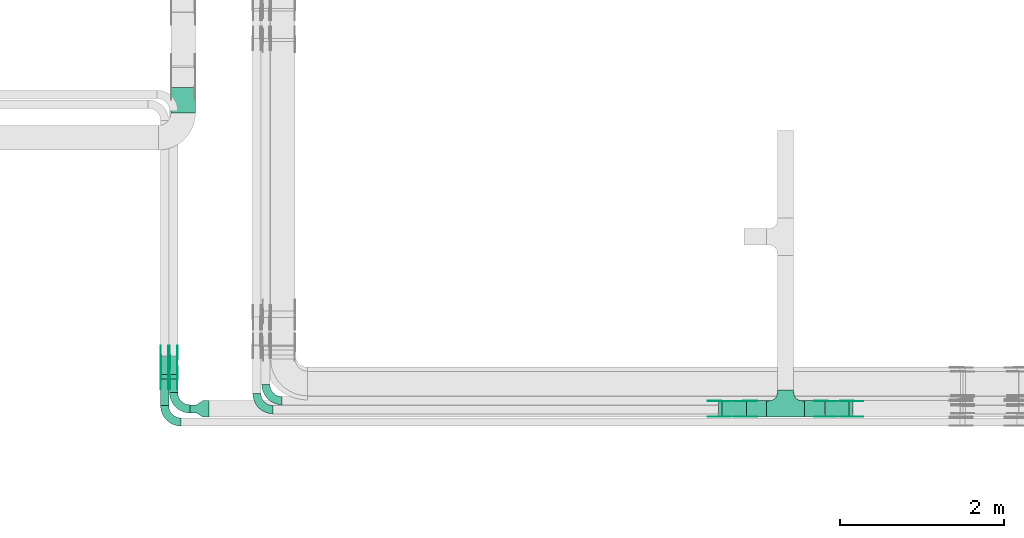
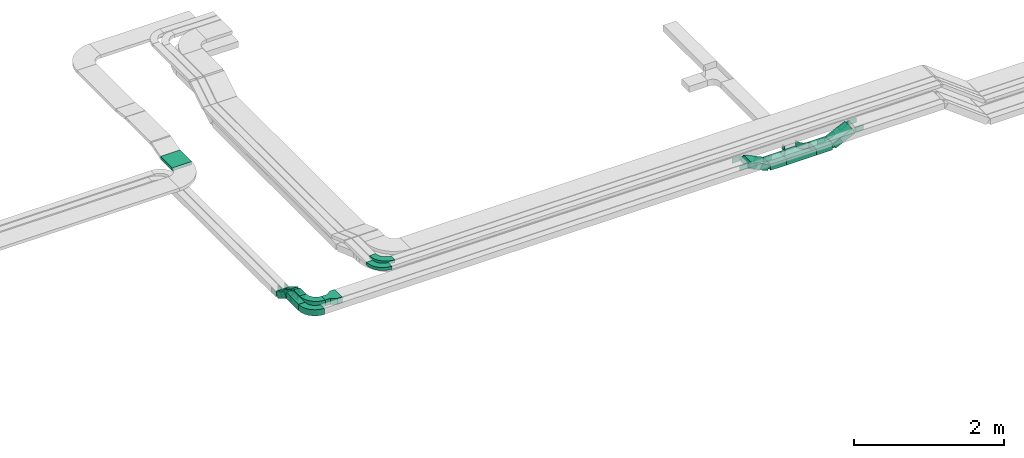
# One storey, part 6 of 28: 38 flow fittings, 9 flow segments.
"""IFC2X3 building model written with IfcOpenShell, lengths in millimetres."""

from ifc_helpers import new_model, entity, si_unit, converted_unit, derived_unit, direction, frame, frame_2d, origin, place, context, subcontext, project, spatial, polyline, circle_curve, parameter, trimmed, segment, composite_curve, rectangle, outline, extrude, faceted_brep, source, transform, mapped, material, type_object, type_shapes, element, save


model = new_model("IFC2X3")

# Units and contexts
model_context = context("Model", 3, precision=0.01, world=origin(), true_north=direction((6.12303176911189e-17, 1.0)))
body_context = subcontext(model_context, "Body", "Model", "MODEL_VIEW")
ifc_project = project(units=[si_unit("LENGTHUNIT", "METRE", prefix="MILLI"), si_unit("AREAUNIT", "SQUARE_METRE"), si_unit("VOLUMEUNIT", "CUBIC_METRE"), converted_unit("PLANEANGLEUNIT", "DEGREE", entity("IfcRatioMeasure", 0.0174532925199433), si_unit("PLANEANGLEUNIT", "RADIAN"), dimensions=[0, 0, 0, 0, 0, 0, 0]), si_unit("MASSUNIT", "GRAM", prefix="KILO"), derived_unit("MASSDENSITYUNIT", [(si_unit("MASSUNIT", "GRAM", prefix="KILO"), 1), (si_unit("LENGTHUNIT", "METRE"), -3)]), derived_unit("MOMENTOFINERTIAUNIT", [(si_unit("LENGTHUNIT", "METRE"), 4)]), si_unit("TIMEUNIT", "SECOND"), si_unit("FREQUENCYUNIT", "HERTZ"), si_unit("THERMODYNAMICTEMPERATUREUNIT", "DEGREE_CELSIUS"), derived_unit("THERMALTRANSMITTANCEUNIT", [(si_unit("MASSUNIT", "GRAM", prefix="KILO"), 1), (si_unit("THERMODYNAMICTEMPERATUREUNIT", "KELVIN"), -1), (si_unit("TIMEUNIT", "SECOND"), -3)]), derived_unit("VOLUMETRICFLOWRATEUNIT", [(si_unit("LENGTHUNIT", "METRE"), 3), (si_unit("TIMEUNIT", "SECOND"), -1)]), derived_unit("MASSFLOWRATEUNIT", [(si_unit("MASSUNIT", "GRAM", prefix="KILO"), 1), (si_unit("TIMEUNIT", "SECOND"), -1)]), derived_unit("ROTATIONALFREQUENCYUNIT", [(si_unit("TIMEUNIT", "SECOND"), -1)]), si_unit("ELECTRICCURRENTUNIT", "AMPERE"), si_unit("ELECTRICVOLTAGEUNIT", "VOLT"), si_unit("POWERUNIT", "WATT"), si_unit("FORCEUNIT", "NEWTON", prefix="KILO"), si_unit("ILLUMINANCEUNIT", "LUX"), si_unit("LUMINOUSFLUXUNIT", "LUMEN"), si_unit("LUMINOUSINTENSITYUNIT", "CANDELA"), derived_unit("USERDEFINED", [(si_unit("MASSUNIT", "GRAM", prefix="KILO"), -1), (si_unit("LENGTHUNIT", "METRE"), -2), (si_unit("TIMEUNIT", "SECOND"), 3), (si_unit("LUMINOUSFLUXUNIT", "LUMEN"), 1)]), derived_unit("LINEARVELOCITYUNIT", [(si_unit("LENGTHUNIT", "METRE"), 1), (si_unit("TIMEUNIT", "SECOND"), -1)]), si_unit("PRESSUREUNIT", "PASCAL"), derived_unit("USERDEFINED", [(si_unit("LENGTHUNIT", "METRE"), -2), (si_unit("MASSUNIT", "GRAM", prefix="KILO"), 1), (si_unit("TIMEUNIT", "SECOND"), -2)]), derived_unit("LINEARFORCEUNIT", [(si_unit("MASSUNIT", "GRAM", prefix="KILO"), 1), (si_unit("LENGTHUNIT", "METRE"), 1), (si_unit("TIMEUNIT", "SECOND"), -2), (si_unit("LENGTHUNIT", "METRE"), -1)]), derived_unit("PLANARFORCEUNIT", [(si_unit("MASSUNIT", "GRAM", prefix="KILO"), 1), (si_unit("LENGTHUNIT", "METRE"), 1), (si_unit("TIMEUNIT", "SECOND"), -2), (si_unit("LENGTHUNIT", "METRE"), -2)])], contexts=[model_context])

# Site, building, storey
site_placement = place(None, frame((0.0, -0.00077364408347762, 0.0)))
site = spatial("IfcSite", under=ifc_project, at=site_placement, CompositionType="ELEMENT")
building_placement = place(site_placement, origin())
building = spatial("IfcBuilding", under=site, at=building_placement, CompositionType="ELEMENT")
storey_placement = place(building_placement, origin())
storey = spatial("IfcBuildingStorey", under=building, at=storey_placement, CompositionType="ELEMENT", Elevation=0.0)

# Flow segments
cable_carrier_segment_type = type_object("IfcCableCarrierSegmentType", PredefinedType="CABLETRAYSEGMENT")
flow_segment_1_placement = place(storey_placement, frame((21923.5985265898, 8360.00006103512, 2950.0)))
element("IfcFlowSegment", 1, at=flow_segment_1_placement, inside=storey, type_object=cable_carrier_segment_type, context=body_context, shape_type="SweptSolid", body=[
    extrude(rectangle(XDim=246.307781920358, YDim=200.0, at=frame_2d((-2.1600499167107e-12, -5.47117906535277e-13), x_axis=(1.0, 0.0))), frame((123.153890960181, 100.0, 0.0)), (0.0, 0.0, 1.0), 100.0),
])
flow_segment_2_placement = place(storey_placement, frame((21217.2907446694, 8360.00006103512, 2950.0)))
element("IfcFlowSegment", 2, at=flow_segment_2_placement, inside=storey, type_object=cable_carrier_segment_type, context=body_context, shape_type="SweptSolid", body=[
    extrude(rectangle(XDim=246.307781920462, YDim=200.0, at=frame_2d((2.16715534406831e-12, 0.0), x_axis=(1.0, 0.0))), frame((123.153890960233, 100.0, 0.0), z_axis=(0.0, 0.0, 1.0), x_axis=(-1.0, 0.0, 0.0)), (0.0, 0.0, 1.0), 100.0),
])
flow_segment_3_placement = place(storey_placement, frame((22173.5030893442, 8360.00006103512, 2960.16660840991)))
element("IfcFlowSegment", 3, at=flow_segment_3_placement, inside=storey, type_object=cable_carrier_segment_type, context=body_context, shape_type="SweptSolid", body=[
    extrude(rectangle(XDim=100.000000000001, YDim=200.0, at=frame_2d((0.0, 1.08713038571295e-12), x_axis=(1.0, 0.0))), frame((21.1309130870434, 100.0, 45.3153893518315), z_axis=(0.906307787036594, 0.0, 0.42261826174082), x_axis=(-0.42261826174082, 0.0, 0.906307787036594)), (0.0, 0.0, 1.0), 328.987213909019),
])
flow_segment_4_placement = place(storey_placement, frame((20873.2684638601, 8360.00006103512, 2960.16660840991)))
element("IfcFlowSegment", 4, at=flow_segment_4_placement, inside=storey, type_object=cable_carrier_segment_type, context=body_context, shape_type="SweptSolid", body=[
    extrude(rectangle(XDim=100.000000000001, YDim=200.0, at=frame_2d((0.0, 0.0), x_axis=(0.0, 1.0))), frame((21.1309130870434, 100.0, 184.351393829014), z_axis=(0.906307787036594, 0.0, -0.42261826174082), x_axis=(0.0, 1.0, 0.0)), (0.0, 0.0, 1.0), 328.987213909019),
])
flow_segment_5_placement = place(storey_placement, frame((14179.9969238282, 12076.2683846925, 3150.0)))
element("IfcFlowSegment", 5, at=flow_segment_5_placement, inside=storey, type_object=cable_carrier_segment_type, context=body_context, shape_type="SweptSolid", body=[
    extrude(rectangle(XDim=310.302662480206, YDim=300.000000000001, at=frame_2d((2.17426077142591e-12, -1.08002495835535e-12), x_axis=(1.0, 0.0))), frame((150.0, 155.151331240117, 0.0), z_axis=(0.0, 0.0, 1.0), x_axis=(0.0, 1.0, 0.0)), (0.0, 0.0, 1.0), 50.0),
])
flow_segment_6_placement = place(storey_placement, frame((14053.724290081, 8501.00006103527, 3100.0)))
element("IfcFlowSegment", 6, at=flow_segment_6_placement, inside=storey, type_object=cable_carrier_segment_type, context=body_context, shape_type="SweptSolid", body=[
    extrude(rectangle(XDim=323.02447462061, YDim=99.9999999999989, at=frame_2d((5.40012479177676e-13, -1.08357767203415e-12), x_axis=(1.0, 0.0))), frame((50.0, 161.512237310309, 0.0), z_axis=(0.0, 0.0, 1.0), x_axis=(0.0, 1.0, 0.0)), (0.0, 0.0, 1.0), 99.9999999999995),
])
flow_segment_7_placement = place(storey_placement, frame((14163.724290081, 8661.0000610351, 3100.0)))
element("IfcFlowSegment", 7, at=flow_segment_7_placement, inside=storey, type_object=cable_carrier_segment_type, context=body_context, shape_type="SweptSolid", body=[
    extrude(rectangle(XDim=163.024474620782, YDim=99.9999999999989, at=frame_2d((5.40012479177676e-13, 0.0), x_axis=(1.0, 0.0))), frame((50.0, 81.5122373103946, 0.0), z_axis=(0.0, 0.0, 1.0), x_axis=(0.0, 1.0, 0.0)), (0.0, 0.0, 1.0), 99.9999999999995),
])
flow_segment_8_placement = place(storey_placement, frame((14163.724290081, 8827.94185525622, 2965.36963880189)))
element("IfcFlowSegment", 8, at=flow_segment_8_placement, inside=storey, type_object=cable_carrier_segment_type, context=body_context, shape_type="SweptSolid", body=[
    extrude(rectangle(XDim=100.0, YDim=99.9999999999989, at=frame_2d((0.0, -6.96331881044898e-13), x_axis=(0.0, 1.0))), frame((50.0, 25.7519037455224, 176.40235736112), z_axis=(0.0, 0.857167300701889, -0.515038074910426), x_axis=(-1.0, 0.0, 0.0)), (0.0, 0.0, 1.0), 259.289553202938),
])
flow_segment_9_placement = place(storey_placement, frame((14053.724290081, 8827.94185525609, 2965.36963880186)))
element("IfcFlowSegment", 9, at=flow_segment_9_placement, inside=storey, type_object=cable_carrier_segment_type, context=body_context, shape_type="SweptSolid", body=[
    extrude(rectangle(XDim=100.000000000001, YDim=99.9999999999989, at=frame_2d((0.0, 0.0), x_axis=(0.0, 1.0))), frame((50.0, 25.7519037454899, 176.402357361164), z_axis=(0.0, 0.857167300702268, -0.515038074909795), x_axis=(-1.0, 0.0, 0.0)), (0.0, 0.0, 1.0), 259.289553203306),
])

# Flow fittings
ifc_material_1 = material(Name="G")
cable_carrier_fitting_type_1 = type_object("IfcCableCarrierFittingType", PredefinedType="NOTDEFINED", material=ifc_material_1)
shared_shape_1 = source(origin(), body_context, "Body", "SweptSolid", [
    extrude(outline(composite_curve([segment(trimmed(circle_curve(frame_2d((-41.4651162790697, 0.0), x_axis=(1.0, 0.0)), 25.0), [parameter(90.0000000000007)], [parameter(270.0)], True, "PARAMETER"), True, "CONTINUOUS"), segment(polyline([(-41.4651162790697, -25.0), (-29.9651162790697, -25.0)]), True, "CONTINUOUS"), segment(polyline([(-29.9651162790697, -25.0), (-28.1046511627907, -38.5)]), True, "CONTINUOUS"), segment(polyline([(-28.1046511627907, -38.5), (99.5348837209303, -38.5)]), True, "CONTINUOUS"), segment(polyline([(99.5348837209303, -38.5), (99.5348837209303, 38.5)]), True, "CONTINUOUS"), segment(polyline([(99.5348837209303, 38.5), (-28.1046511627907, 38.5)]), True, "CONTINUOUS"), segment(polyline([(-28.1046511627907, 38.5), (-29.9651162790697, 25.0)]), True, "CONTINUOUS"), segment(polyline([(-29.9651162790697, 25.0), (-41.46511627907, 25.0)]), True, "CONTINUOUS")], self_intersect=False)), frame((41.4651162790697, 0.0, 0.0), z_axis=(0.0, 0.0, -1.0), x_axis=(1.0, 0.0, 0.0)), (0.0, 0.0, -1.0), 2.0),
])
type_shapes(cable_carrier_fitting_type_1, [shared_shape_1])
for number, where, z_axis, x_axis in (
    (10, (22504.5538583707, 8364.54006102496, 3150.0), (0.0, -1.0, 0.0), (-0.906307787036633, 0.0, -0.422618261740735)),
    (11, (22182.8778202929, 8555.46006104527, 3000.0), (0.0, 1.0, 0.0), (-1.0, 0.0, 0.0)),
    (12, (21204.3192328867, 8364.54006102496, 3000.0), (0.0, -1.0, 0.0), (1.0, 0.0, 0.0)),
    (13, (20882.6431948103, 8364.54006102497, 3150.0), (0.0, -1.0, 0.0), (-1.0, 0.0, 0.0)),
    (14, (14168.2642900708, 8840.00006103512, 3150.0), (-1.0, 0.0, 0.0), (0.0, 0.857167300702083, -0.515038074910103)),
    (15, (14259.1842900912, 9089.6419833875, 3000.0), (1.0, 0.0, 0.0), (0.0, 1.0, 0.0)),
    (16, (14149.1842900912, 8840.00006103497, 3150.0), (1.0, 0.0, 0.0), (0.0, -1.0, 0.0)),
    (17, (14149.1842900912, 9089.64198338777, 3000.0), (1.0, 0.0, 0.0), (0.0, 1.0, 0.0)),
):
    element("IfcFlowFitting", number, at=place(storey_placement, frame(where, z_axis=z_axis, x_axis=x_axis)), inside=storey, type_object=cable_carrier_fitting_type_1, material=ifc_material_1, context=body_context, shape_type="MappedRepresentation", body=[
        mapped(shared_shape_1, transform((0.0, 0.0, 0.0), scale=1.0)),
    ])
cable_carrier_fitting_type_2 = type_object("IfcCableCarrierFittingType", PredefinedType="NOTDEFINED", material=ifc_material_1)
shared_shape_2 = source(origin(), body_context, "Body", "SweptSolid", [
    extrude(outline(composite_curve([segment(trimmed(circle_curve(frame_2d((-41.4651162790697, 0.0), x_axis=(1.0, 0.0)), 25.0), [parameter(90.0000000000007)], [parameter(270.0)], True, "PARAMETER"), True, "CONTINUOUS"), segment(polyline([(-41.4651162790697, -25.0), (-29.9651162790697, -25.0)]), True, "CONTINUOUS"), segment(polyline([(-29.9651162790697, -25.0), (-28.1046511627907, -38.5)]), True, "CONTINUOUS"), segment(polyline([(-28.1046511627907, -38.5), (99.5348837209303, -38.5)]), True, "CONTINUOUS"), segment(polyline([(99.5348837209303, -38.5), (99.5348837209303, 38.5)]), True, "CONTINUOUS"), segment(polyline([(99.5348837209303, 38.5), (-28.1046511627907, 38.5)]), True, "CONTINUOUS"), segment(polyline([(-28.1046511627907, 38.5), (-29.9651162790697, 25.0)]), True, "CONTINUOUS"), segment(polyline([(-29.9651162790697, 25.0), (-41.46511627907, 25.0)]), True, "CONTINUOUS")], self_intersect=False)), frame((41.4651162790697, 0.0, 0.0)), (0.0, 0.0, 1.0), 2.0),
])
type_shapes(cable_carrier_fitting_type_2, [shared_shape_2])
for number, where, z_axis, x_axis in (
    (18, (22504.5538583707, 8555.46006104528, 3150.0), (0.0, 1.0, 0.0), (-0.906307787036633, 0.0, -0.422618261740735)),
    (19, (22182.8778202929, 8364.54006102496, 3000.0), (0.0, -1.0, 0.0), (-1.0, 0.0, 0.0)),
    (20, (21204.3192328867, 8555.46006104528, 3000.0), (0.0, 1.0, 0.0), (1.0, 0.0, 0.0)),
    (21, (20882.6431948103, 8555.46006104528, 3150.0), (0.0, 1.0, 0.0), (-1.0, 0.0, 0.0)),
    (22, (14259.1842900912, 8840.00006103512, 3150.0), (1.0, 0.0, 0.0), (0.0, 0.857167300702083, -0.515038074910103)),
    (23, (14168.2642900708, 9089.6419833875, 3000.0), (-1.0, 0.0, 0.0), (0.0, 1.0, 0.0)),
    (24, (14058.2642900708, 8840.00006103498, 3150.0), (-1.0, 0.0, 0.0), (0.0, -1.0, 0.0)),
    (25, (14058.2642900708, 9089.64198338776, 3000.0), (-1.0, 0.0, 0.0), (0.0, 1.0, 0.0)),
):
    element("IfcFlowFitting", number, at=place(storey_placement, frame(where, z_axis=z_axis, x_axis=x_axis)), inside=storey, type_object=cable_carrier_fitting_type_2, material=ifc_material_1, context=body_context, shape_type="MappedRepresentation", body=[
        mapped(shared_shape_2, transform((0.0, 0.0, 0.0), scale=1.0)),
    ])
cable_carrier_fitting_type_3 = type_object("IfcCableCarrierFittingType", PredefinedType="NOTDEFINED", material=ifc_material_1)
shared_shape_3 = source(origin(), body_context, "Body", "SweptSolid", [
    extrude(outline(composite_curve([segment(trimmed(circle_curve(frame_2d((-41.4651162790697, 0.0), x_axis=(1.0, 0.0)), 25.0), [parameter(90.0000000000007)], [parameter(270.0)], True, "PARAMETER"), True, "CONTINUOUS"), segment(polyline([(-41.4651162790697, -25.0), (-29.9651162790697, -25.0)]), True, "CONTINUOUS"), segment(polyline([(-29.9651162790697, -25.0), (-28.1046511627907, -38.5)]), True, "CONTINUOUS"), segment(polyline([(-28.1046511627907, -38.5), (99.5348837209303, -38.5)]), True, "CONTINUOUS"), segment(polyline([(99.5348837209303, -38.5), (99.5348837209303, 38.5)]), True, "CONTINUOUS"), segment(polyline([(99.5348837209303, 38.5), (-28.1046511627907, 38.5)]), True, "CONTINUOUS"), segment(polyline([(-28.1046511627907, 38.5), (-29.9651162790697, 25.0)]), True, "CONTINUOUS"), segment(polyline([(-29.9651162790697, 25.0), (-41.46511627907, 25.0)]), True, "CONTINUOUS")], self_intersect=False)), frame((41.4651162790697, 0.0, 0.0), z_axis=(0.0, 0.0, -1.0), x_axis=(1.0, 0.0, 0.0)), (0.0, 0.0, -1.0), 2.0),
])
type_shapes(cable_carrier_fitting_type_3, [shared_shape_3])
for number, where, z_axis, x_axis in (
    (26, (22504.5538583707, 8553.46006104528, 3150.0), (0.0, 1.0, 0.0), (1.0, 0.0, 0.0)),
    (27, (22182.8778202929, 8366.54006102496, 3000.0), (0.0, -1.0, 0.0), (0.906307787036611, 0.0, 0.422618261740783)),
    (28, (21204.3192328867, 8553.46006104528, 3000.0), (0.0, 1.0, 0.0), (-0.906307787036601, 0.0, 0.422618261740805)),
    (29, (20882.6431948103, 8553.46006104528, 3150.0), (0.0, 1.0, 0.0), (0.906307787036601, 0.0, -0.422618261740805)),
    (30, (14257.1842900912, 8840.00006103513, 3150.0), (1.0, 0.0, 0.0), (0.0, -1.0, 0.0)),
    (31, (14170.2642900708, 9089.64198338751, 3000.0), (-1.0, 0.0, 0.0), (0.0, -0.857167300701907, 0.515038074910396)),
    (32, (14060.2642900708, 8840.00006103497, 3150.0), (-1.0, 0.0, 0.0), (0.0, 0.857167300702034, -0.515038074910184)),
    (33, (14060.2642900708, 9089.64198338777, 3000.0), (-1.0, 0.0, 0.0), (0.0, -0.85716730070229, 0.515038074909759)),
):
    element("IfcFlowFitting", number, at=place(storey_placement, frame(where, z_axis=z_axis, x_axis=x_axis)), inside=storey, type_object=cable_carrier_fitting_type_3, material=ifc_material_1, context=body_context, shape_type="MappedRepresentation", body=[
        mapped(shared_shape_3, transform((0.0, 0.0, 0.0), scale=1.0)),
    ])
cable_carrier_fitting_type_4 = type_object("IfcCableCarrierFittingType", PredefinedType="NOTDEFINED", material=ifc_material_1)
shared_shape_4 = source(origin(), body_context, "Body", "SweptSolid", [
    extrude(outline(composite_curve([segment(trimmed(circle_curve(frame_2d((-41.4651162790697, 0.0), x_axis=(1.0, 0.0)), 25.0), [parameter(90.0000000000007)], [parameter(270.0)], True, "PARAMETER"), True, "CONTINUOUS"), segment(polyline([(-41.4651162790697, -25.0), (-29.9651162790697, -25.0)]), True, "CONTINUOUS"), segment(polyline([(-29.9651162790697, -25.0), (-28.1046511627907, -38.5)]), True, "CONTINUOUS"), segment(polyline([(-28.1046511627907, -38.5), (99.5348837209303, -38.5)]), True, "CONTINUOUS"), segment(polyline([(99.5348837209303, -38.5), (99.5348837209303, 38.5)]), True, "CONTINUOUS"), segment(polyline([(99.5348837209303, 38.5), (-28.1046511627907, 38.5)]), True, "CONTINUOUS"), segment(polyline([(-28.1046511627907, 38.5), (-29.9651162790697, 25.0)]), True, "CONTINUOUS"), segment(polyline([(-29.9651162790697, 25.0), (-41.46511627907, 25.0)]), True, "CONTINUOUS")], self_intersect=False)), frame((41.4651162790697, 0.0, 0.0)), (0.0, 0.0, 1.0), 2.0),
])
type_shapes(cable_carrier_fitting_type_4, [shared_shape_4])
for number, where, z_axis, x_axis in (
    (34, (22504.5538583707, 8366.54006102496, 3150.0), (0.0, -1.0, 0.0), (1.0, 0.0, 0.0)),
    (35, (22182.8778202929, 8553.46006104527, 3000.0), (0.0, 1.0, 0.0), (0.906307787036611, 0.0, 0.422618261740783)),
    (36, (21204.3192328867, 8366.54006102496, 3000.0), (0.0, -1.0, 0.0), (-0.906307787036601, 0.0, 0.422618261740805)),
    (37, (20882.6431948103, 8366.54006102497, 3150.0), (0.0, -1.0, 0.0), (0.906307787036601, 0.0, -0.422618261740805)),
    (38, (14170.2642900708, 8840.00006103513, 3150.0), (-1.0, 0.0, 0.0), (0.0, -1.0, 0.0)),
    (39, (14257.1842900912, 9089.64198338751, 3000.0), (1.0, 0.0, 0.0), (0.0, -0.857167300701907, 0.515038074910396)),
    (40, (14147.1842900912, 8840.00006103497, 3150.0), (1.0, 0.0, 0.0), (0.0, 0.857167300702034, -0.515038074910184)),
    (41, (14147.1842900912, 9089.64198338778, 3000.0), (1.0, 0.0, 0.0), (0.0, -0.85716730070229, 0.515038074909759)),
):
    element("IfcFlowFitting", number, at=place(storey_placement, frame(where, z_axis=z_axis, x_axis=x_axis)), inside=storey, type_object=cable_carrier_fitting_type_4, material=ifc_material_1, context=body_context, shape_type="MappedRepresentation", body=[
        mapped(shared_shape_4, transform((0.0, 0.0, 0.0), scale=1.0)),
    ])
ifc_material_2 = material()
cable_carrier_fitting_type_5 = type_object("IfcCableCarrierFittingType", Name="470_DKC_S5_Variable Angle Elbow 0-45:-", PredefinedType="NOTDEFINED", material=ifc_material_2)
shared_shape_5 = source(origin(), body_context, "Body", "SweptSolid", [
    extrude(outline(composite_curve([segment(polyline([(-100.750000000001, -150.25), (-99.7499999999994, -150.25)]), True, "CONTINUOUS"), segment(trimmed(circle_curve(frame_2d((-99.7499999999997, 99.7499999999995), x_axis=(0.0, -1.0)), 250.0), [parameter(0.0)], [parameter(90.0000000000001)], True, "PARAMETER"), True, "CONTINUOUS"), segment(polyline([(150.25, 99.75), (150.25, 100.749999999999)]), True, "CONTINUOUS"), segment(polyline([(150.25, 100.749999999999), (50.25, 100.75)]), True, "CONTINUOUS"), segment(polyline([(50.25, 100.75), (50.25, 99.7499999999998)]), True, "CONTINUOUS"), segment(trimmed(circle_curve(frame_2d((-99.7499999999997, 99.7499999999995), x_axis=(0.0, -1.0)), 150.0), [parameter(0.0)], [parameter(90.0000000000001)], True, "PARAMETER"), False, "CONTINUOUS"), segment(polyline([(-99.7499999999994, -50.2500000000003), (-100.750000000001, -50.2500000000003)]), True, "CONTINUOUS"), segment(polyline([(-100.750000000001, -50.2500000000003), (-100.750000000001, -150.25)]), True, "CONTINUOUS")], self_intersect=False)), frame((-100.249999999991, 100.249999999992, -25.0)), (0.0, 0.0, 1.0), 49.9999999999997),
])
type_shapes(cable_carrier_fitting_type_5, [shared_shape_5])
for number, where, z_axis, x_axis, name in (
    (42, (15339.9969238281, 8560.00006103507, 3375.0), (0.0, 0.0, 1.0), (0.0, -1.0, 0.0), "470_DKC_S5_Variable Angle Elbow 0-45:-"),
    (43, (15229.9969238281, 8450.00006103519, 3375.0), (0.0, 0.0, 1.0), (0.0, -1.0, 0.0), "470_DKC_S5_Variable Angle Elbow 0-45:-"),
):
    element("IfcFlowFitting", number, at=place(storey_placement, frame(where, z_axis=z_axis, x_axis=x_axis)), inside=storey, type_object=cable_carrier_fitting_type_5, material=ifc_material_2, Name=name, ObjectType="470_DKC_S5_Variable Angle Elbow 0-45:-", context=body_context, shape_type="MappedRepresentation", body=[
        mapped(shared_shape_5, transform((0.0, 0.0, 0.0), scale=1.0)),
    ])
cable_carrier_fitting_type_6 = type_object("IfcCableCarrierFittingType", PredefinedType="NOTDEFINED", material=ifc_material_2)
shared_shape_6 = source(origin(), body_context, "Body", "Brep", [
    faceted_brep([(-103.407417371087, -174.118095489753, 50.0), (-100.0, -200.0, 50.0), (-100.0, -230.0, 50.0), (-99.1999999999932, -230.0, 50.0), (-99.1999999999933, -200.0, 50.0), (-102.634676710055, -173.911040253671, 50.0), (-112.704639298522, -149.600000000004, 50.0), (-128.723636456391, -128.7236364564, 50.0), (-149.599999999996, -112.704639298532, 50.0), (-173.911040253663, -102.634676710066, 50.0), (-200.0, -99.2000000000044, 50.0), (-230.0, -99.2000000000044, 50.0), (-230.0, -100.0, 50.0), (-200.0, -100.0, 50.0), (-174.118095489746, -103.407417371099, 50.0), (-150.0, -113.397459621561, 50.0), (-129.28932188134, -129.28932188135, 50.0), (-113.39745962155, -150.0, 50.0), (230.0, -100.0, 50.0), (230.0, -99.2000000000044, 50.0), (200.0, -99.2000000000097, 50.0), (173.911040253722, -102.634676710071, 50.0), (149.60000000005, -112.704639298537, 50.0), (128.723636456439, -128.723636456403, 50.0), (112.704639298563, -149.600000000006, 50.0), (102.634676710086, -173.911040253673, 50.0), (99.2000000000121, -200.0, 50.0), (99.2000000000069, -230.0, 50.0), (100.0, -230.0, 50.0), (100.0, -200.0, 50.0), (103.407417371119, -174.118095489755, 50.0), (113.397459621593, -150.0, 50.0), (129.289321881391, -129.289321881354, 50.0), (150.0, -113.397459621567, 50.0), (174.118095489805, -103.407417371105, 50.0), (200.0, -100.0, 50.0), (230.0, 99.1999999999954, 50.0), (230.0, 100.0, 50.0), (-230.0, 100.0, 50.0), (-230.0, 99.1999999999954, 50.0), (-230.0, -100.0, -50.0), (-230.0, 100.0, -50.0), (230.0, 100.0, -50.0), (230.0, -100.0, -50.0), (200.0, -100.0, -50.0), (174.118095489805, -103.407417371105, -50.0), (150.0, -113.397459621567, -50.0), (129.289321881391, -129.289321881354, -50.0), (113.397459621593, -150.0, -50.0), (103.407417371119, -174.118095489755, -50.0), (100.0, -200.0, -50.0), (100.0, -230.0, -50.0), (-100.0, -230.0, -50.0), (-100.0, -200.0, -50.0), (-103.407417371087, -174.118095489753, -50.0), (-113.39745962155, -150.0, -50.0), (-129.28932188134, -129.28932188135, -50.0), (-150.0, -113.397459621561, -50.0), (-174.118095489746, -103.407417371099, -50.0), (-200.0, -100.0, -50.0), (-100.0, -200.0, -49.1999999999851), (99.2000000000069, -230.0, -49.1999999999851), (-99.1999999999932, -230.0, -49.1999999999851), (-99.1999999999933, -200.0, -49.1999999999851), (-200.0, -99.2000000000044, -49.1999999999851), (-230.0, -99.2000000000044, -49.1999999999851), (230.0, -99.2000000000044, -49.1999999999851), (200.0, -99.2000000000044, -49.1999999999851), (-230.0, 99.1999999999954, -49.1999999999851), (-200.0, -100.0, -49.1999999999851), (200.0, -100.0, -49.1999999999851), (230.0, 99.1999999999954, -49.1999999999851), (99.2000000000121, -200.0, -49.1999999999851), (100.0, -200.0, -49.1999999999851), (-173.911040253663, -102.634676710066, -49.1999999999851), (-149.599999999996, -112.704639298532, -49.1999999999851), (-128.723636456391, -128.7236364564, -49.1999999999851), (-112.704639298522, -149.600000000004, -49.1999999999851), (-102.634676710055, -173.911040253671, -49.1999999999851), (102.634676710086, -173.911040253674, -49.1999999999851), (112.704639298563, -149.600000000007, -49.1999999999851), (128.723636456439, -128.723636456403, -49.1999999999851), (149.60000000005, -112.704639298537, -49.1999999999851), (173.911040253721, -102.634676710071, -49.1999999999851)], [[[0, 1, 2, 3, 4, 5, 6, 7, 8, 9, 10, 11, 12, 13, 14, 15, 16, 17]], [[18, 19, 20, 21, 22, 23, 24, 25, 26, 27, 28, 29, 30, 31, 32, 33, 34, 35]], [[36, 37, 38, 39]], [[40, 41, 42, 43, 44, 45, 46, 47, 48, 49, 50, 51, 52, 53, 54, 55, 56, 57, 58, 59]], [[2, 1, 60, 53, 52]], [[3, 2, 52, 51, 28, 27, 61, 62]], [[4, 3, 62, 63]], [[11, 10, 64, 65]], [[20, 19, 66, 67]], [[39, 38, 41, 40, 12, 11, 65, 68]], [[13, 12, 40, 59, 69]], [[18, 35, 70, 44, 43]], [[19, 18, 43, 42, 37, 36, 71, 66]], [[27, 26, 72, 61]], [[29, 28, 51, 50, 73]], [[38, 37, 42, 41]], [[36, 39, 68, 71]], [[68, 65, 64, 74, 75, 76, 77, 78, 63, 62, 61, 72, 79, 80, 81, 82, 83, 67, 66, 71]], [[14, 13, 69, 59, 58]], [[15, 14, 58, 57]], [[57, 56, 16, 15]], [[17, 16, 56, 55]], [[0, 17, 55, 54]], [[1, 0, 54, 53, 60]], [[5, 78, 77, 6]], [[6, 77, 76, 7]], [[63, 78, 5, 4]], [[8, 75, 74, 9]], [[9, 74, 64, 10]], [[7, 76, 75, 8]], [[21, 83, 82, 22]], [[22, 82, 81, 23]], [[67, 83, 21, 20]], [[24, 80, 79, 25]], [[25, 79, 72, 26]], [[23, 81, 80, 24]], [[30, 29, 73, 50, 49]], [[31, 30, 49, 48]], [[32, 31, 48, 47]], [[34, 33, 46, 45]], [[34, 45, 44, 70, 35]], [[46, 33, 32, 47]]]),
])
type_shapes(cable_carrier_fitting_type_6, [shared_shape_6])
flow_fitting_1_placement = place(storey_placement, frame((21693.5985265898, 8460.0000610351, 3000.0), z_axis=(0.0, 0.0, 1.0), x_axis=(-1.0, 0.0, 0.0)))
element("IfcFlowFitting", 44, at=flow_fitting_1_placement, inside=storey, type_object=cable_carrier_fitting_type_6, material=ifc_material_2, Name="470_DKC_S5_T", context=body_context, shape_type="MappedRepresentation", body=[
    mapped(shared_shape_6, transform((0.0, 0.0, 0.0), scale=1.0)),
])
cable_carrier_fitting_type_7 = type_object("IfcCableCarrierFittingType", Name="470_DKC_S5_Variable Angle Elbow 0-45:-", PredefinedType="NOTDEFINED", material=ifc_material_2)
shared_shape_7 = source(origin(), body_context, "Body", "SweptSolid", [
    extrude(outline(composite_curve([segment(polyline([(-100.749999999999, -150.250000000001), (-99.7499999999981, -150.250000000001)]), True, "CONTINUOUS"), segment(trimmed(circle_curve(frame_2d((-99.7500000000006, 99.7499999999987), x_axis=(0.0, -1.0)), 250.0), [parameter(0.0)], [parameter(90.0000000000001)], True, "PARAMETER"), True, "CONTINUOUS"), segment(polyline([(150.249999999999, 99.7500000000013), (150.249999999999, 100.750000000001)]), True, "CONTINUOUS"), segment(polyline([(150.249999999999, 100.750000000001), (50.2499999999992, 100.750000000001)]), True, "CONTINUOUS"), segment(polyline([(50.2499999999992, 100.750000000001), (50.2499999999992, 99.7500000000002)]), True, "CONTINUOUS"), segment(trimmed(circle_curve(frame_2d((-99.7500000000006, 99.7499999999987), x_axis=(0.0, -1.0)), 150.0), [parameter(0.0)], [parameter(90.0000000000001)], True, "PARAMETER"), False, "CONTINUOUS"), segment(polyline([(-99.7499999999989, -50.2500000000011), (-100.75, -50.2500000000011)]), True, "CONTINUOUS"), segment(polyline([(-100.75, -50.2500000000011), (-100.749999999999, -150.250000000001)]), True, "CONTINUOUS")], self_intersect=False)), frame((-100.249999999991, 100.249999999992, -50.0)), (0.0, 0.0, 1.0), 100.0),
])
type_shapes(cable_carrier_fitting_type_7, [shared_shape_7])
for number, where, z_axis, x_axis, name in (
    (45, (14213.724290081, 8460.00006103512, 3150.0), (0.0, 0.0, 1.0), (0.0, -1.0, 0.0), "470_DKC_S5_Variable Angle Elbow 0-45:-"),
    (46, (14103.724290081, 8300.00006103529, 3150.0), (0.0, 0.0, 1.0), (0.0, -1.0, 0.0), "470_DKC_S5_Variable Angle Elbow 0-45:-"),
):
    element("IfcFlowFitting", number, at=place(storey_placement, frame(where, z_axis=z_axis, x_axis=x_axis)), inside=storey, type_object=cable_carrier_fitting_type_7, material=ifc_material_2, Name=name, ObjectType="470_DKC_S5_Variable Angle Elbow 0-45:-", context=body_context, shape_type="MappedRepresentation", body=[
        mapped(shared_shape_7, transform((0.0, 0.0, 0.0), scale=1.0)),
    ])
cable_carrier_fitting_type_8 = type_object("IfcCableCarrierFittingType", PredefinedType="NOTDEFINED", material=ifc_material_2)
shared_shape_8 = source(origin(), body_context, "Body", "SweptSolid", [
    extrude(outline(polyline([(-115.0, -100.0), (-38.3333333333284, -100.0), (38.3333333333252, -50.0), (115.0, -50.0), (115.0, 50.0), (38.3333333333382, 50.0), (-38.3333333333284, 100.0), (-115.0, 100.0), (-115.0, -100.0)])), frame((115.0, 0.0, -50.0)), (0.0, 0.0, 1.0), 100.0),
])
type_shapes(cable_carrier_fitting_type_8, [shared_shape_8])
flow_fitting_2_placement = place(storey_placement, frame((14644.724290081, 8460.00006103511, 3150.0), z_axis=(0.0, 0.0, 1.0), x_axis=(-1.0, 0.0, 0.0)))
element("IfcFlowFitting", 47, at=flow_fitting_2_placement, inside=storey, type_object=cable_carrier_fitting_type_8, material=ifc_material_2, Name="470_DKC_S5_adapter", context=body_context, shape_type="MappedRepresentation", body=[
    mapped(shared_shape_8, transform((0.0, 0.0, 0.0), scale=1.0)),
])

save(model, "model.ifc")
